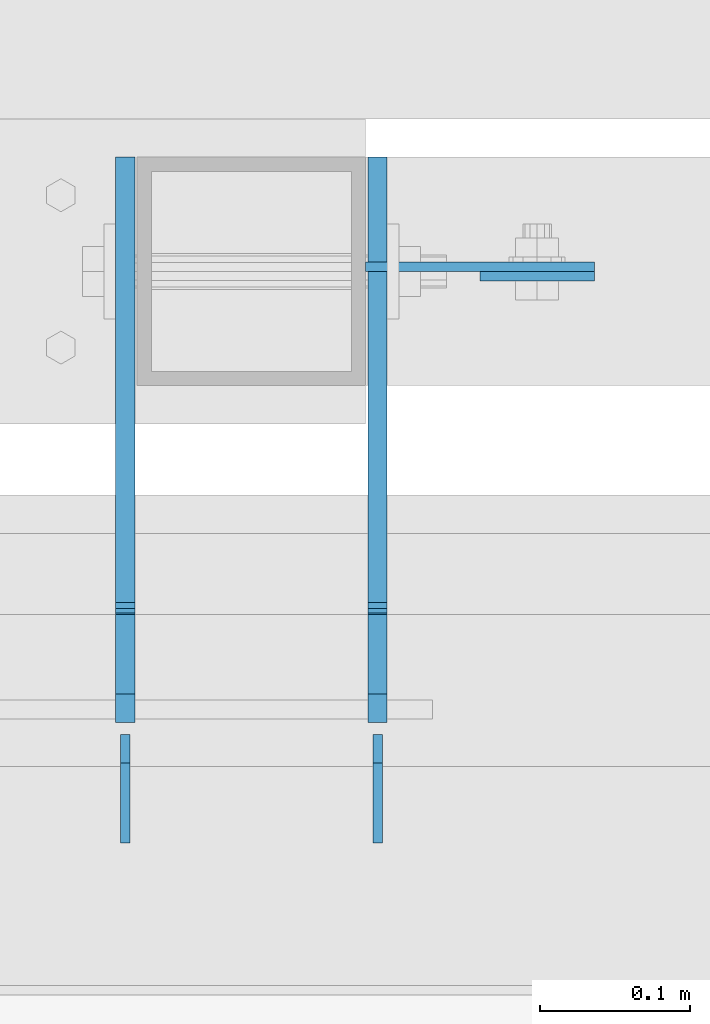
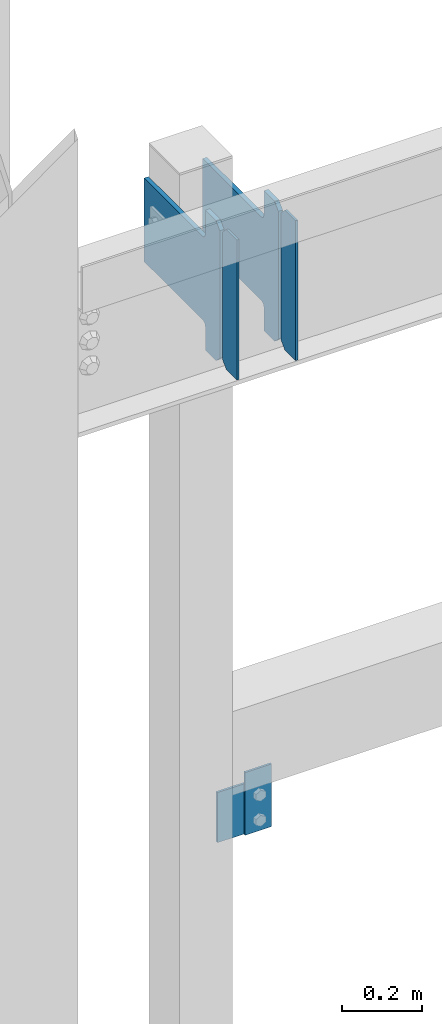
# One storey, part 3429 of 3843: 6 plates, 3 elements without a shape of their own.
"""IFC2X3 building model written with IfcOpenShell, lengths in millimetres."""

import ifcopenshell
import ifcopenshell.guid

model = None  # the IFC model being written
_history = None  # IfcOwnerHistory: only IFC2X3 demands one
_inside = {}  # id of a spatial element -> (the spatial element, [elements in it])
_under = {}  # id of a project, library or spatial element -> (it, [spatial elements below it])
_declared = {}  # id of a project -> (the project, [libraries it declares])
_typed = {}  # id of a type object -> (the type object, [elements of that type])
_made_of = {}  # id of a material, layer set ... -> (it, [elements and type objects made of it])


def new_model(schema):
    """Start an empty IFC model of exactly this schema.

    Asked for "IFC4X3", IfcOpenShell would pick the latest addendum, in which some entities
    have other attributes; the version numbers below select the first issue.
    IFC2X3 requires an IfcOwnerHistory on every rooted entity: one is made here for all.
    """
    global model, _history
    if schema == "IFC4X3":
        model = ifcopenshell.file(schema_version=(4, 3, 0, 0))
    else:
        model = ifcopenshell.file(schema=schema)
    _inside.clear()
    _under.clear()
    _declared.clear()
    _typed.clear()
    _made_of.clear()
    _history = None
    if model.schema == "IFC2X3":
        org = make("IfcOrganization", Name="unknown")
        user = make(
            "IfcPersonAndOrganization",
            ThePerson=make("IfcPerson", FamilyName="unknown"),
            TheOrganization=org,
        )
        app = make(
            "IfcApplication",
            ApplicationDeveloper=org,
            Version="unknown",
            ApplicationFullName="unknown",
            ApplicationIdentifier="unknown",
        )
        _history = make(
            "IfcOwnerHistory",
            OwningUser=user,
            OwningApplication=app,
            ChangeAction="ADDED",
            CreationDate=0,
        )
    return model


def make(cls, **values):
    """One entity of the class cls with the attributes given. An attribute that is None is left unset."""
    return model.create_entity(
        cls, **{name: value for name, value in values.items() if value is not None}
    )


def rooted(cls, **values):
    """An entity with a GlobalId (a new one), such as an element, a storey or a relation."""
    return make(cls, GlobalId=ifcopenshell.guid.new(), OwnerHistory=_history, **values)


def si_unit(unit_type, name, prefix=None):
    """IfcSIUnit, for example si_unit("LENGTHUNIT", "METRE", prefix="MILLI")."""
    return make("IfcSIUnit", UnitType=unit_type, Prefix=prefix, Name=name)


def assignment(units):
    """IfcUnitAssignment: the units of a project."""
    return None if units is None else make("IfcUnitAssignment", Units=units)


def point(xyz):
    """IfcCartesianPoint."""
    return None if xyz is None else make("IfcCartesianPoint", Coordinates=xyz)


def direction(xyz):
    """IfcDirection."""
    return None if xyz is None else make("IfcDirection", DirectionRatios=xyz)


def frame(location, z_axis=None, x_axis=None):
    """IfcAxis2Placement3D, a coordinate frame: its origin and axes. An axis left out is left unset."""
    return make(
        "IfcAxis2Placement3D",
        Location=point(location),
        Axis=direction(z_axis),
        RefDirection=direction(x_axis),
    )


def origin_with_axes():
    """The frame at (0, 0, 0) with the z axis (0, 0, 1) and the x axis (1, 0, 0) written out."""
    return frame((0.0, 0.0, 0.0), z_axis=(0.0, 0.0, 1.0), x_axis=(1.0, 0.0, 0.0))


def place(relative_to, where):
    """IfcLocalPlacement: puts the frame where relative to a parent placement (None: the world)."""
    return make(
        "IfcLocalPlacement", PlacementRelTo=relative_to, RelativePlacement=where
    )


def context(
    kind, dimensions, precision=None, world=None, true_north=None, identifier=None
):
    """IfcGeometricRepresentationContext, for example the 3D "Model" context."""
    return make(
        "IfcGeometricRepresentationContext",
        ContextIdentifier=identifier,
        ContextType=kind,
        CoordinateSpaceDimension=dimensions,
        Precision=precision,
        WorldCoordinateSystem=world,
        TrueNorth=true_north,
    )


def subcontext(parent, identifier, kind, view, scale=None):
    """IfcGeometricRepresentationSubContext, for example "Body" below "Model"."""
    return make(
        "IfcGeometricRepresentationSubContext",
        ContextIdentifier=identifier,
        ContextType=kind,
        ParentContext=parent,
        TargetScale=scale,
        TargetView=view,
    )


def project(units=None, contexts=None):
    """IfcProject with its units and contexts."""
    return rooted(
        "IfcProject",
        Name="project",
        RepresentationContexts=contexts,
        UnitsInContext=assignment(units),
    )


def spatial(cls, under=None, at=None, **own):
    """A site, building, storey or space (cls), placed at a placement, below another one or the project."""
    s = rooted(cls, ObjectPlacement=at, **own)
    if under is not None:
        _under.setdefault(under.id(), (under, []))[1].append(s)
    return s


def faces_of(points, faces, orient=None, outer=None):
    """IfcFace entities. A face is a list of loops; a loop is a list of indices into points, from 0.

    orient and outer hold one flag for each loop. By default every Orientation is true, the
    first loop of a face is its IfcFaceOuterBound and the others are IfcFaceBound.
    """
    made = []
    for i, loops in enumerate(faces):
        bounds = []
        for j, loop in enumerate(loops):
            is_outer = j == 0 if outer is None else outer[i][j]
            bounds.append(
                make(
                    "IfcFaceOuterBound" if is_outer else "IfcFaceBound",
                    Bound=make("IfcPolyLoop", Polygon=[points[k] for k in loop]),
                    Orientation=True if orient is None else orient[i][j],
                )
            )
        made.append(make("IfcFace", Bounds=bounds))
    return made


def faceted_brep(points, faces, orient=None, outer=None, voids=None):
    """IfcFacetedBrep: a solid bounded by flat faces; with voids (closed shells), ...WithVoids."""
    shared = [point(p) for p in points]
    hull = make("IfcClosedShell", CfsFaces=faces_of(shared, faces, orient, outer))
    if voids is None:
        return make("IfcFacetedBrep", Outer=hull)
    return make(
        "IfcFacetedBrepWithVoids",
        Outer=hull,
        Voids=[
            make(cls, CfsFaces=faces_of(shared, fs, o, b)) for cls, fs, o, b in voids
        ],
    )


def shape(context_of_items, identifier, shape_type, items):
    """IfcShapeRepresentation: the items that make up one representation, for example the "Body"."""
    return make(
        "IfcShapeRepresentation",
        ContextOfItems=context_of_items,
        RepresentationIdentifier=identifier,
        RepresentationType=shape_type,
        Items=items,
    )


def material(Name=None, Category=None):
    """IfcMaterial."""
    return make("IfcMaterial", Name=Name, Category=Category)


def made_of(thing, what):
    """Note that an element or type object is made of a material, layer set ...; save() writes the relation."""
    if what is not None:
        _made_of.setdefault(what.id(), (what, []))[1].append(thing)
    return thing


def type_object(cls, material=None, **own):
    """A type object (cls), such as IfcWallType, which elements share."""
    return made_of(rooted(cls, **own), material)


def element(
    cls,
    number,
    at=None,
    inside=None,
    cuts=None,
    type_object=None,
    material=None,
    context=None,
    identifier="Body",
    shape_type=None,
    held_by="IfcProductDefinitionShape",
    body=None,
    shapes=None,
    **own,
):
    """One element of the class cls, such as IfcWall. Its Tag is "e" and its number.

    at: its placement. inside: the storey or other place that contains it. cuts: it is an
    opening in that element (IfcRelVoidsElement). A single representation is given by context,
    identifier, shape_type and body (its items); several are given by shapes. held_by: the class
    of the entity that holds the representations. save() writes the other relations.
    """
    e = rooted(cls, Tag="e%d" % number, ObjectPlacement=at, **own)
    if body is not None:
        shapes = [shape(context, identifier, shape_type, body)]
    if shapes is not None:
        e.Representation = make(held_by, Representations=shapes)
    if inside is not None:
        _inside.setdefault(inside.id(), (inside, []))[1].append(e)
    if cuts is not None:
        rooted(
            "IfcRelVoidsElement", RelatingBuildingElement=cuts, RelatedOpeningElement=e
        )
    if type_object is not None:
        _typed.setdefault(type_object.id(), (type_object, []))[1].append(e)
    return made_of(e, material)


def aggregate(whole, parts):
    """IfcRelAggregates: a whole, such as a stair, and the parts it consists of."""
    return rooted("IfcRelAggregates", RelatingObject=whole, RelatedObjects=parts)


def save(model, path):
    """Write the relations noted so far, then the file.

    IfcRelAggregates (storeys below a building ...), IfcRelContainedInSpatialStructure (elements
    in a storey), IfcRelDefinesByType, IfcRelAssociatesMaterial and IfcRelDeclares: one each for
    every whole, place, type object, material and project.
    """
    for whole, parts in _under.values():
        aggregate(whole, parts)
    for where, things in _inside.values():
        rooted(
            "IfcRelContainedInSpatialStructure",
            RelatedElements=things,
            RelatingStructure=where,
        )
    for kind, things in _typed.values():
        rooted("IfcRelDefinesByType", RelatedObjects=things, RelatingType=kind)
    for what, things in _made_of.values():
        rooted("IfcRelAssociatesMaterial", RelatedObjects=things, RelatingMaterial=what)
    for by, libraries in _declared.values():
        rooted("IfcRelDeclares", RelatingContext=by, RelatedDefinitions=libraries)
    model.write(path)


model = new_model("IFC2X3")

# Units and contexts
model_context = context("Model", 3, precision=1e-05, world=origin_with_axes())
body_context = subcontext(model_context, "Body", "Model", "MODEL_VIEW")
ifc_project = project(units=[si_unit("LENGTHUNIT", "METRE", prefix="MILLI"), si_unit("AREAUNIT", "SQUARE_METRE"), si_unit("VOLUMEUNIT", "CUBIC_METRE"), si_unit("MASSUNIT", "GRAM", prefix="KILO"), si_unit("TIMEUNIT", "SECOND"), si_unit("PLANEANGLEUNIT", "RADIAN"), si_unit("SOLIDANGLEUNIT", "STERADIAN"), si_unit("THERMODYNAMICTEMPERATUREUNIT", "DEGREE_CELSIUS"), si_unit("LUMINOUSINTENSITYUNIT", "LUMEN")], contexts=[model_context])

# Site, building, storey
site_placement = place(None, origin_with_axes())
site = spatial("IfcSite", under=ifc_project, at=site_placement, CompositionType="ELEMENT")
building_placement = place(site_placement, origin_with_axes())
building = spatial("IfcBuilding", under=site, at=building_placement, Name="Undefined", CompositionType="ELEMENT")
storey_placement = place(building_placement, origin_with_axes())
storey = spatial("IfcBuildingStorey", under=building, at=storey_placement, Name="Undefined", CompositionType="ELEMENT", Elevation=0.0)

# Assembly, plate
assembly_1_placement = place(storey_placement, origin_with_axes())
assembly_1 = element("IfcElementAssembly", 1, at=assembly_1_placement, inside=storey, Name="POST", AssemblyPlace="NOTDEFINED", PredefinedType="RIGID_FRAME")
ifc_material = material(Name="STEEL/A572-50")
plate_type_1 = type_object("IfcPlateType", PredefinedType="NOTDEFINED")
plate_1_placement = place(assembly_1_placement, frame((42926.0, 92522.675, 34455.1), z_axis=(0.0, 0.0, -1.0), x_axis=(1.0, 0.0, 0.0)))
plate_1 = element("IfcPlate", 2, at=plate_1_placement, type_object=plate_type_1, material=ifc_material, Name="PLATE", context=body_context, shape_type="Brep", body=[
    faceted_brep([(0.0, -3.17499999999927, 0.0), (1.52795109897852e-10, -3.17500000000291, 152.400000000009), (1.52795109897852e-10, 3.17500000000291, 152.400000000009), (0.0, 3.17499999999927, 0.0), (152.399993896484, -3.17500000000291, 152.399993896484), (152.399993896484, 3.17500000000291, 152.399993896484), (152.399998474109, -3.17500000000291, 0.0), (152.399998474109, 3.17500000000291, 0.0)], [[[0, 1, 2, 3]], [[1, 4, 5, 2]], [[4, 6, 7, 5]], [[6, 0, 3, 7]], [[5, 7, 3, 2]], [[6, 4, 1, 0]]]),
])
aggregate(assembly_1, [plate_1])

assembly_2_placement = place(storey_placement, origin_with_axes())
assembly_2 = element("IfcElementAssembly", 3, at=assembly_2_placement, inside=storey, Name="BEAM", AssemblyPlace="NOTDEFINED", PredefinedType="RIGID_FRAME")
plate_type_2 = type_object("IfcPlateType", PredefinedType="NOTDEFINED")
plate_2_placement = place(assembly_2_placement, frame((43078.3999938965, 92516.325, 34302.7000061036), z_axis=(-1.0, 0.0, 0.0), x_axis=(0.0, 0.0, 1.0)))
plate_2 = element("IfcPlate", 4, at=plate_2_placement, type_object=plate_type_2, material=ifc_material, Name="PLATE", context=body_context, shape_type="Brep", body=[
    faceted_brep([(0.0, -3.17499999999927, 0.0), (0.0, -3.17499999999927, 76.1999969482422), (0.0, 3.17499999999927, 76.1999969482422), (0.0, 3.17499999999927, 0.0), (190.5, -3.17500000000291, 76.1999969482422), (190.5, 3.17500000000291, 76.1999969482422), (190.5, -3.17500000000291, -3.63797880709171e-12), (190.5, 3.17500000000291, -3.63797880709171e-12)], [[[0, 1, 2, 3]], [[1, 4, 5, 2]], [[4, 6, 7, 5]], [[6, 0, 3, 7]], [[5, 7, 3, 2]], [[6, 4, 1, 0]]]),
])
aggregate(assembly_2, [plate_2])

# Assembly, plates
assembly_3_placement = place(storey_placement, origin_with_axes())
assembly_3 = element("IfcElementAssembly", 5, at=assembly_3_placement, inside=storey, Name="BEAM", AssemblyPlace="NOTDEFINED", PredefinedType="RIGID_FRAME")
plate_type_3 = type_object("IfcPlateType", PredefinedType="NOTDEFINED")
plate_3_placement = place(assembly_3_placement, frame((42765.6625, 92138.5, 35996.5625), z_axis=(0.0, 0.0, 1.0), x_axis=(0.0, 1.0, 0.0)))
plate_3 = element("IfcPlate", 6, at=plate_3_placement, type_object=plate_type_3, material=ifc_material, Name="PLATE", context=body_context, shape_type="Brep", body=[
    faceted_brep([(0.0, -3.17499999999927, 0.0), (0.0, -3.17500000000291, 425.449999999997), (0.0, 3.17500000000291, 425.449999999997), (0.0, 3.17499999999927, 0.0), (53.1812477111816, -3.17500000000291, 425.450012207031), (53.1812477111816, 3.17500000000291, 425.450012207031), (72.2312469482422, -3.17500000000291, 406.400012969971), (72.2312469482422, 3.17500000000291, 406.400012969971), (72.2312469482422, -3.17500000000291, 19.0499992370605), (72.2312469482422, 3.17500000000291, 19.0499992370605), (53.1812477111816, -3.17500000000291, 0.0), (53.1812477111816, 3.17500000000291, 0.0)], [[[0, 1, 2, 3]], [[1, 4, 5, 2]], [[4, 6, 7, 5]], [[6, 8, 9, 7]], [[8, 10, 11, 9]], [[10, 0, 3, 11]], [[5, 7, 9, 11, 3, 2]], [[10, 8, 6, 4, 1, 0]]]),
])
plate_4_placement = place(assembly_3_placement, frame((42933.9375, 92138.5, 35996.5625), z_axis=(0.0, 0.0, 1.0), x_axis=(0.0, 1.0, 0.0)))
plate_4 = element("IfcPlate", 7, at=plate_4_placement, type_object=plate_type_3, material=ifc_material, Name="PLATE", context=body_context, shape_type="Brep", body=[
    faceted_brep([(0.0, -3.17499999999927, 0.0), (0.0, -3.17500000000291, 425.449999999997), (0.0, 3.17500000000291, 425.449999999997), (0.0, 3.17499999999927, 0.0), (53.1812477111816, -3.17500000000291, 425.450012207031), (53.1812477111816, 3.17500000000291, 425.450012207031), (72.2312469482422, -3.17500000000291, 406.400012969971), (72.2312469482422, 3.17500000000291, 406.400012969971), (72.2312469482422, -3.17500000000291, 19.0499992370605), (72.2312469482422, 3.17500000000291, 19.0499992370605), (53.1812477111816, -3.17500000000291, 0.0), (53.1812477111816, 3.17500000000291, 0.0)], [[[0, 1, 2, 3]], [[1, 4, 5, 2]], [[4, 6, 7, 5]], [[6, 8, 9, 7]], [[8, 10, 11, 9]], [[10, 0, 3, 11]], [[5, 7, 9, 11, 3, 2]], [[10, 8, 6, 4, 1, 0]]]),
])
plate_type_4 = type_object("IfcPlateType", PredefinedType="NOTDEFINED")
plate_5_placement = place(assembly_3_placement, frame((42765.6625, 92218.66875, 35996.5625), z_axis=(0.0, 0.0, 1.0), x_axis=(0.0, 1.0, 0.0)))
plate_5 = element("IfcPlate", 8, at=plate_5_placement, type_object=plate_type_4, material=ifc_material, Name="PLATE", context=body_context, shape_type="Brep", body=[
    faceted_brep([(0.0, -6.34999999999854, 19.0499992370605), (0.0, -6.34999999999854, 406.400000762937), (0.0, 6.34999999999854, 406.400000762937), (0.0, 6.34999999999854, 19.0499992370605), (19.0499992370605, -6.34999999999854, 425.449999999997), (19.0499992370605, 6.34999999999854, 425.449999999997), (72.2312469482422, -6.35000000000582, 425.450012207031), (72.2312469482422, 6.35000000000582, 425.450012207031), (72.2312469482422, -6.35000000000582, 350.837505912779), (72.2312469482422, 6.35000000000582, 350.837505912779), (73.1979768708261, -6.35000000000582, 345.977426394733), (73.1979768708261, 6.35000000000582, 345.977426394733), (75.9509907713073, -6.35000000000582, 341.857249926579), (75.9509907713073, 6.35000000000582, 341.857249926579), (80.0711672394682, -6.35000000000582, 339.104236026105), (80.0711672394682, 6.35000000000582, 339.104236026105), (84.9312467575073, -6.35000000000582, 338.137506103514), (84.9312467575073, 6.35000000000582, 338.137506103514), (377.03125, -6.35000000000582, 338.137506103514), (377.03125, 6.35000000000582, 338.137506103514), (377.03125, -6.35000000000582, 84.1374969482422), (377.03125, 6.35000000000582, 84.1374969482422), (84.9312467575073, -6.35000000000582, 84.1374969482422), (84.9312467575073, 6.35000000000582, 84.1374969482422), (80.0711672394682, -6.35000000000582, 83.170767025651), (80.0711672394682, 6.35000000000582, 83.170767025651), (75.9509907713073, -6.35000000000582, 80.4177531251771), (75.9509907713073, 6.35000000000582, 80.4177531251771), (73.1979768708261, -6.35000000000582, 76.2975766570235), (73.1979768708261, 6.35000000000582, 76.2975766570235), (72.2312469482422, -6.35000000000582, 71.4374971389771), (72.2312469482422, 6.35000000000582, 71.4374971389771), (72.2312469482422, -6.35000000000582, 0.0), (72.2312469482422, 6.35000000000582, 0.0), (19.0499992370605, -6.34999999999854, 0.0), (19.0499992370605, 6.34999999999854, 0.0)], [[[0, 1, 2, 3]], [[1, 4, 5, 2]], [[4, 6, 7, 5]], [[6, 8, 9, 7]], [[8, 10, 11, 9]], [[10, 12, 13, 11]], [[12, 14, 15, 13]], [[14, 16, 17, 15]], [[16, 18, 19, 17]], [[18, 20, 21, 19]], [[20, 22, 23, 21]], [[22, 24, 25, 23]], [[24, 26, 27, 25]], [[26, 28, 29, 27]], [[28, 30, 31, 29]], [[30, 32, 33, 31]], [[32, 34, 35, 33]], [[34, 0, 3, 35]], [[5, 7, 9, 11, 13, 15, 17, 19, 21, 23, 25, 27, 29, 31, 33, 35, 3, 2]], [[34, 32, 30, 28, 26, 24, 22, 20, 18, 16, 14, 12, 10, 8, 6, 4, 1, 0]]]),
])
plate_6_placement = place(assembly_3_placement, frame((42933.9375, 92218.66875, 35996.5625), z_axis=(0.0, 0.0, 1.0), x_axis=(0.0, 1.0, 0.0)))
plate_6 = element("IfcPlate", 9, at=plate_6_placement, type_object=plate_type_4, material=ifc_material, Name="PLATE", context=body_context, shape_type="Brep", body=[
    faceted_brep([(0.0, -6.34999999999854, 19.0499992370605), (0.0, -6.34999999999854, 406.400000762937), (0.0, 6.34999999999854, 406.400000762937), (0.0, 6.34999999999854, 19.0499992370605), (19.0499992370605, -6.34999999999854, 425.449999999997), (19.0499992370605, 6.34999999999854, 425.449999999997), (72.2312469482422, -6.35000000000582, 425.450012207031), (72.2312469482422, 6.35000000000582, 425.450012207031), (72.2312469482422, -6.35000000000582, 350.837505912779), (72.2312469482422, 6.35000000000582, 350.837505912779), (73.1979768708261, -6.35000000000582, 345.977426394733), (73.1979768708261, 6.35000000000582, 345.977426394733), (75.9509907713073, -6.35000000000582, 341.857249926579), (75.9509907713073, 6.35000000000582, 341.857249926579), (80.0711672394682, -6.35000000000582, 339.104236026105), (80.0711672394682, 6.35000000000582, 339.104236026105), (84.9312467575073, -6.35000000000582, 338.137506103514), (84.9312467575073, 6.35000000000582, 338.137506103514), (377.03125, -6.35000000000582, 338.137506103514), (377.03125, 6.35000000000582, 338.137506103514), (377.03125, -6.35000000000582, 84.1374969482422), (377.03125, 6.35000000000582, 84.1374969482422), (84.9312467575073, -6.35000000000582, 84.1374969482422), (84.9312467575073, 6.35000000000582, 84.1374969482422), (80.0711672394682, -6.35000000000582, 83.170767025651), (80.0711672394682, 6.35000000000582, 83.170767025651), (75.9509907713073, -6.35000000000582, 80.4177531251771), (75.9509907713073, 6.35000000000582, 80.4177531251771), (73.1979768708261, -6.35000000000582, 76.2975766570235), (73.1979768708261, 6.35000000000582, 76.2975766570235), (72.2312469482422, -6.35000000000582, 71.4374971389771), (72.2312469482422, 6.35000000000582, 71.4374971389771), (72.2312469482422, -6.35000000000582, 0.0), (72.2312469482422, 6.35000000000582, 0.0), (19.0499992370605, -6.34999999999854, 0.0), (19.0499992370605, 6.34999999999854, 0.0)], [[[0, 1, 2, 3]], [[1, 4, 5, 2]], [[4, 6, 7, 5]], [[6, 8, 9, 7]], [[8, 10, 11, 9]], [[10, 12, 13, 11]], [[12, 14, 15, 13]], [[14, 16, 17, 15]], [[16, 18, 19, 17]], [[18, 20, 21, 19]], [[20, 22, 23, 21]], [[22, 24, 25, 23]], [[24, 26, 27, 25]], [[26, 28, 29, 27]], [[28, 30, 31, 29]], [[30, 32, 33, 31]], [[32, 34, 35, 33]], [[34, 0, 3, 35]], [[5, 7, 9, 11, 13, 15, 17, 19, 21, 23, 25, 27, 29, 31, 33, 35, 3, 2]], [[34, 32, 30, 28, 26, 24, 22, 20, 18, 16, 14, 12, 10, 8, 6, 4, 1, 0]]]),
])
aggregate(assembly_3, [plate_3, plate_5, plate_6, plate_4])

save(model, "model.ifc")
